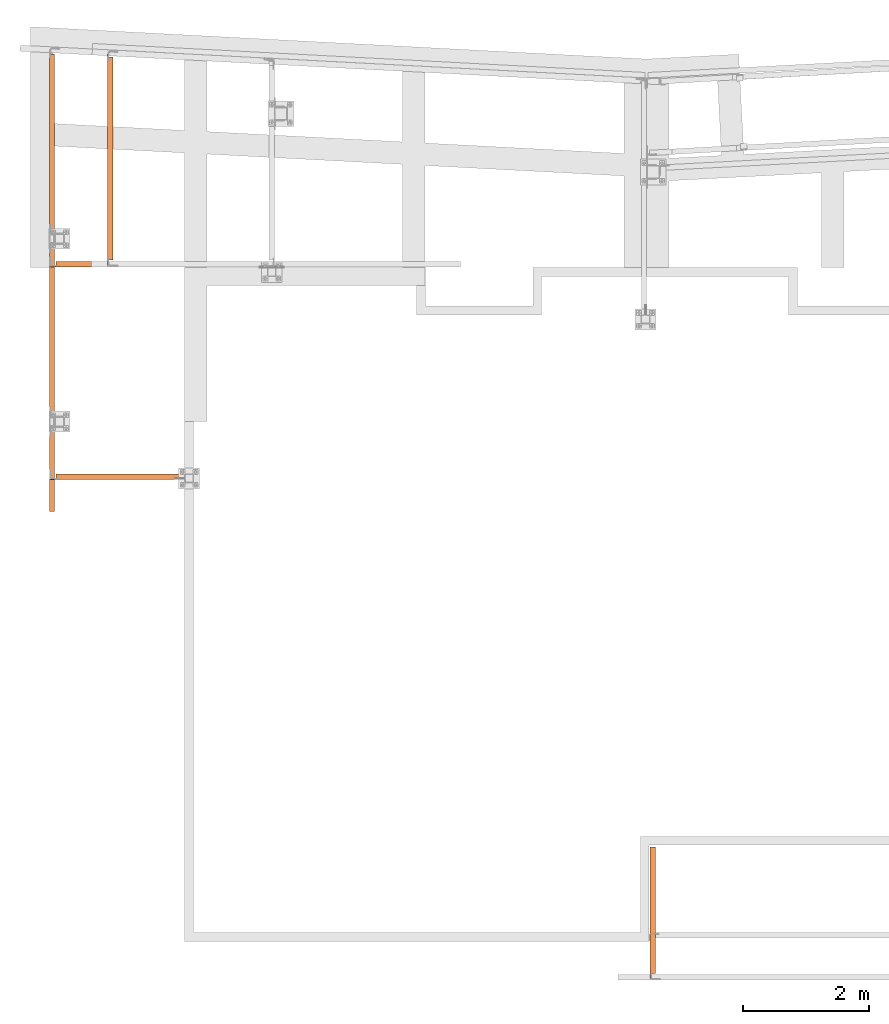
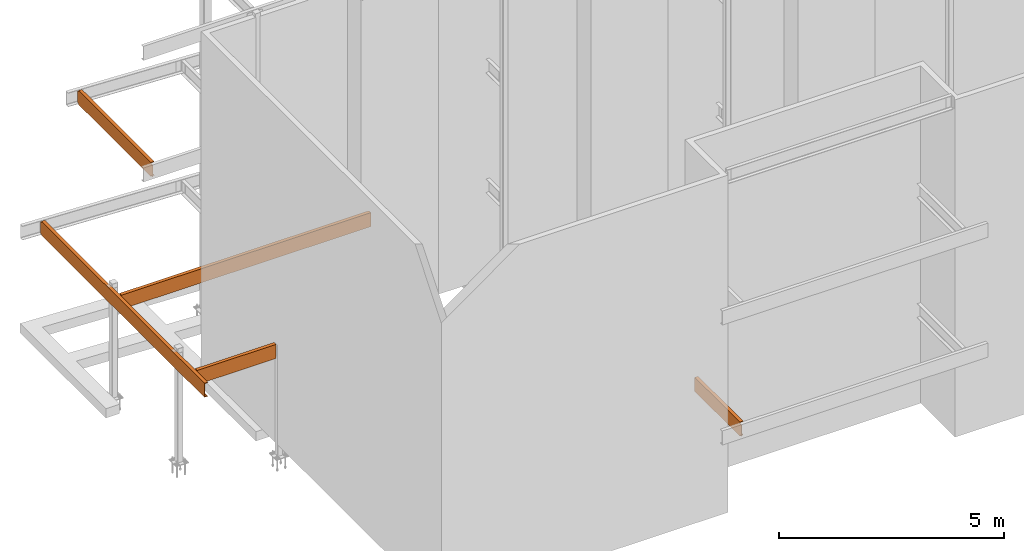
# One storey, part 11 of 89: 5 proxies.
"""IFC4 building model written with IfcOpenShell, lengths in feet."""

from ifc_helpers import new_model, entity, si_unit, converted_unit, derived_unit, direction, frame, origin, place, context, subcontext, project, spatial, faceted_brep, source, transform, mapped, material, constituent, constituent_set, type_object, type_shapes, element, save


model = new_model("IFC4")

# Units and contexts
model_context = context("Model", 3, precision=0.0001, world=origin(), true_north=direction((6.12303176911189e-17, 1.0)))
body_context = subcontext(model_context, "Body", "Model", "MODEL_VIEW")
ifc_project = project(units=[converted_unit("LENGTHUNIT", "FOOT", entity("IfcRatioMeasure", 0.3048), si_unit("LENGTHUNIT", "METRE"), dimensions=[1, 0, 0, 0, 0, 0, 0]), converted_unit("AREAUNIT", "SQUARE FOOT", entity("IfcRatioMeasure", 0.09290304), si_unit("AREAUNIT", "SQUARE_METRE"), dimensions=[2, 0, 0, 0, 0, 0, 0]), converted_unit("VOLUMEUNIT", "CUBIC FOOT", entity("IfcRatioMeasure", 0.028316846592), si_unit("VOLUMEUNIT", "CUBIC_METRE"), dimensions=[3, 0, 0, 0, 0, 0, 0]), si_unit("PLANEANGLEUNIT", "RADIAN"), si_unit("MASSUNIT", "GRAM", prefix="KILO"), derived_unit("MASSDENSITYUNIT", [(si_unit("MASSUNIT", "GRAM", prefix="KILO"), 1), (si_unit("LENGTHUNIT", "METRE"), -3)]), derived_unit("MOMENTOFINERTIAUNIT", [(si_unit("LENGTHUNIT", "METRE"), 4)]), si_unit("TIMEUNIT", "SECOND"), si_unit("FREQUENCYUNIT", "HERTZ"), si_unit("THERMODYNAMICTEMPERATUREUNIT", "DEGREE_CELSIUS"), derived_unit("THERMALTRANSMITTANCEUNIT", [(si_unit("MASSUNIT", "GRAM", prefix="KILO"), 1), (si_unit("THERMODYNAMICTEMPERATUREUNIT", "KELVIN"), -1), (si_unit("TIMEUNIT", "SECOND"), -3)]), derived_unit("VOLUMETRICFLOWRATEUNIT", [(si_unit("LENGTHUNIT", "METRE"), 3), (si_unit("TIMEUNIT", "SECOND"), -1)]), si_unit("ELECTRICCURRENTUNIT", "AMPERE"), si_unit("ELECTRICVOLTAGEUNIT", "VOLT"), si_unit("POWERUNIT", "WATT"), si_unit("FORCEUNIT", "NEWTON"), si_unit("ILLUMINANCEUNIT", "LUX"), si_unit("LUMINOUSFLUXUNIT", "LUMEN"), si_unit("LUMINOUSINTENSITYUNIT", "CANDELA"), derived_unit("USERDEFINED", [(si_unit("MASSUNIT", "GRAM", prefix="KILO"), -1), (si_unit("LENGTHUNIT", "METRE"), -2), (si_unit("TIMEUNIT", "SECOND"), 3), (si_unit("LUMINOUSFLUXUNIT", "LUMEN"), 1)]), derived_unit("LINEARVELOCITYUNIT", [(si_unit("LENGTHUNIT", "METRE"), 1), (si_unit("TIMEUNIT", "SECOND"), -1)]), si_unit("PRESSUREUNIT", "PASCAL"), derived_unit("USERDEFINED", [(si_unit("LENGTHUNIT", "METRE"), -2), (si_unit("MASSUNIT", "GRAM", prefix="KILO"), 1), (si_unit("TIMEUNIT", "SECOND"), -2)]), derived_unit("LINEARFORCEUNIT", [(si_unit("MASSUNIT", "GRAM", prefix="KILO"), 1), (si_unit("LENGTHUNIT", "METRE"), 1), (si_unit("TIMEUNIT", "SECOND"), -2), (si_unit("LENGTHUNIT", "METRE"), -1)]), derived_unit("PLANARFORCEUNIT", [(si_unit("MASSUNIT", "GRAM", prefix="KILO"), 1), (si_unit("LENGTHUNIT", "METRE"), 1), (si_unit("TIMEUNIT", "SECOND"), -2), (si_unit("LENGTHUNIT", "METRE"), -2)])], contexts=[model_context])

# Site, building, storey
site_placement = place(None, origin())
site = spatial("IfcSite", under=ifc_project, at=site_placement, CompositionType="ELEMENT")
building_placement = place(site_placement, frame((-472.238160486, -49.138065117, 0.0)))
building = spatial("IfcBuilding", under=site, at=building_placement, CompositionType="ELEMENT")
storey_placement = place(building_placement, origin())
storey = spatial("IfcBuildingStorey", under=building, at=storey_placement, Name="Level 1", CompositionType="ELEMENT", Elevation=0.0)

# Proxies
ifc_material_1 = material(Name="Color 7720", Category="Materials")
ifc_material_2 = material()
ifc_constituent_1 = constituent(ifc_material_2)
ifc_constituent_2 = constituent(ifc_material_1, Name="Color 7720", Category="Materials")
ifc_constituent_set_1 = constituent_set(constituents=[ifc_constituent_1, ifc_constituent_2])
building_element_proxy_type_1 = type_object("IfcBuildingElementProxyType", Name="c271", PredefinedType="NOTDEFINED", material=ifc_constituent_set_1)
shared_shape_1 = source(origin(), body_context, "Body", "Brep", [
    faceted_brep([(0.0333333333333314, 0.0, 1.125), (0.0, 0.0, 1.125), (0.0, 0.0, 0.125), (0.0333333333333314, 0.0, 0.125), (0.283333333333331, 6.84374999999966, 1.25), (0.283333333333331, 6.84374999999966, 1.21666594419212), (0.0775163152265748, 6.84374999999966, 1.18236429742145), (0.06009413825808, 6.84374999999966, 1.17618476966831), (0.0458638286993107, 6.84374999999966, 1.16438573990163), (0.0365646960660513, 6.84374999999966, 1.14840935276805), (0.0333333333333314, 6.84374999999966, 1.13020833333333), (0.0333333333333314, 6.84374999999966, 0.11979166666667), (0.0365646960660513, 6.84374999999966, 0.10159064723195), (0.0458638286993107, 6.84374999999966, 0.0856142600983691), (0.06009413825808, 6.84374999999966, 0.0738152303316895), (0.0775163152265748, 6.84374999999966, 0.0676357025785492), (0.283333333333331, 6.84374999999966, 0.0333340558078792), (0.283333333333331, 6.84374999999966, 0.0), (0.0, 6.84374999999966, 0.0), (0.0, 6.84374999999966, 1.25), (0.0, 0.267661647187992, 0.0992784763485499), (0.0, 0.258629449216187, 0.11279611588277), (0.0, 0.24511180968193, 0.121828313854641), (0.0, 0.229166666666742, 0.125), (0.0, 0.229166666666742, 1.125), (0.0, 0.24511180968193, 1.12817168614536), (0.0, 0.258629449216187, 1.13720388411723), (0.0, 0.267661647187992, 1.15072152365145), (0.0, 0.270833333333371, 1.16666666666667), (0.0, 0.270833333333371, 1.25), (0.0, 0.270833333333371, 0.0), (0.0, 0.270833333333371, 0.0833333333333304), (0.0750833333333389, 0.270833333333371, 0.0), (0.283333333333331, 0.270833333333371, 0.0), (0.283333333333331, 0.270833333333371, 0.0333340558078792), (0.0775163152265748, 0.270833333333371, 0.0676357025785492), (0.06009413825808, 0.270833333333371, 0.073815230331693), (0.0750833333333389, 0.270833333333371, 0.0684986647192396), (0.0458638286993391, 0.270379628790693, 0.0856142600983834), (0.0486147577663019, 0.270833333333371, 0.0833333333333552), (0.0365646960660229, 0.266116703996545, 0.101590647231946), (0.0379105062004328, 0.267661647187992, 0.099278476348541), (0.0333333333333314, 0.248159867599952, 0.11979166666667), (0.0345753056403737, 0.258629449216187, 0.112796115882773), (0.0333333333333599, 0.24511180968193, 0.121828313854641), (0.0333333333333599, 0.248159867599952, 1.13020833333333), (0.0333333333333599, 0.24511180968193, 1.12817168614536), (0.0333333333333599, 0.229166666666742, 1.125), (0.0333333333333599, 0.229166666666742, 0.125), (0.0365646960660513, 0.266116703996545, 1.14840935276805), (0.0345753056403737, 0.258629449216187, 1.13720388411722), (0.0458638286992823, 0.270379628790693, 1.16438573990164), (0.0379105062004328, 0.267661647187992, 1.15072152365146), (0.06009413825808, 0.270833333333371, 1.17618476966832), (0.0486147577663019, 0.270833333333371, 1.16666666666669), (0.0750833333333389, 0.270833333333371, 1.18150133528076), (0.0775163152265748, 0.270833333333371, 1.18236429742144), (0.283333333333331, 0.270833333333371, 1.21666594419212), (0.283333333333331, 0.270833333333371, 1.25), (0.0750833333333389, 0.270833333333371, 1.25)], [[[0, 1, 2, 3]], [[4, 5, 6, 7, 8, 9, 10, 11, 12, 13, 14, 15, 16, 17, 18, 19]], [[20, 21, 22, 23, 2, 1, 24, 25, 26, 27, 28, 29, 19, 18, 30, 31]], [[32, 30, 18, 17, 33]], [[33, 17, 16, 34]], [[34, 16, 15, 35]], [[35, 15, 14, 36, 37]], [[14, 13, 38, 39, 36]], [[13, 12, 40, 41, 38]], [[12, 11, 42, 43, 40]], [[44, 42, 11, 10, 45, 46, 47, 0, 3, 48]], [[10, 9, 49, 50, 45]], [[9, 8, 51, 52, 49]], [[8, 7, 53, 54, 51]], [[55, 53, 7, 6, 56]], [[56, 6, 5, 57]], [[57, 5, 4, 58]], [[58, 4, 19, 29, 59]], [[24, 1, 0, 47]], [[25, 24, 47, 46]], [[26, 25, 46, 45, 50]], [[27, 26, 50, 49, 52]], [[28, 27, 52, 51, 54]], [[56, 57, 58, 59, 29, 28, 54, 53, 55]], [[34, 33, 32, 30, 31, 39, 36, 37, 35]], [[20, 31, 39, 38, 41]], [[21, 20, 41, 40, 43]], [[22, 21, 43, 42, 44]], [[44, 48, 23, 22]], [[48, 3, 2, 23]]]),
])
type_shapes(building_element_proxy_type_1, [shared_shape_1])
proxy_1_placement = place(building_placement, frame((230.666666666667, 971.072916666667, 8.52083333333333)))
element("IfcBuildingElementProxy", 1, at=proxy_1_placement, inside=storey, type_object=building_element_proxy_type_1, material=ifc_material_1, Name="c271:c271", ObjectType="c271:c271", PredefinedType="NOTDEFINED", context=body_context, shape_type="MappedRepresentation", body=[
    mapped(shared_shape_1, transform((0.0, 0.0, 0.0), scale=1.0)),
])
ifc_constituent_3 = constituent(ifc_material_2)
ifc_constituent_4 = constituent(ifc_material_1, Name="Color 7720", Category="Materials")
ifc_constituent_set_2 = constituent_set(constituents=[ifc_constituent_3, ifc_constituent_4])
building_element_proxy_type_2 = type_object("IfcBuildingElementProxyType", Name="c732", PredefinedType="NOTDEFINED", material=ifc_constituent_set_2)
shared_shape_2 = source(origin(), body_context, "Body", "Brep", [
    faceted_brep([(0.0, 0.0, 1.25), (0.0, 0.0, 0.0), (0.283333333333331, 0.0, 0.0), (0.283333333333331, 0.0, 0.0333340558078827), (0.0775163152265748, 0.0, 0.0676357025785528), (0.0600941382581084, 0.0, 0.073815230331693), (0.0458638286993107, 0.0, 0.0856142600983727), (0.0365646960660513, 0.0, 0.101590647231953), (0.0333333333333314, 0.0, 0.119791666666673), (0.0333333333333314, 0.0, 1.13020833333334), (0.0365646960660513, 0.0, 1.14840935276805), (0.0458638286993107, 0.0, 1.16438573990164), (0.0600941382581084, 0.0, 1.17618476966831), (0.0775163152265748, 0.0, 1.18236429742145), (0.283333333333331, 0.0, 1.21666594419212), (0.283333333333331, 0.0, 1.25), (0.0, 23.9212245567654, 0.125000000000004), (0.0, 23.9212245567654, 1.125), (0.0333333333333314, 23.9212245567654, 1.125), (0.0333333333333314, 23.9212245567654, 0.125000000000004), (0.0, 23.8011127470835, 0.121828313854643), (0.0, 23.7875951075494, 0.112796115882771), (0.0, 23.7785629095774, 0.0992784763485517), (0.0, 23.7753912234321, 0.0833333333333321), (0.0, 23.7753912234321, 0.0), (0.0, 23.7753912234321, 1.25), (0.0, 23.7753912234321, 1.16666666666667), (0.0, 23.7785629095774, 1.15072152365146), (0.0, 23.7875951075494, 1.13720388411723), (0.0, 23.8011127470835, 1.12817168614536), (0.0, 23.8170578900988, 1.125), (0.0, 23.8170578900988, 0.125000000000002), (0.283333333333331, 23.7657285498773, 0.0), (0.0989583333333428, 23.7753912234321, 0.0), (0.283333333333331, 23.7657285498773, 0.0333340558078827), (0.0989583333333428, 23.7753912234321, 0.0640621568245852), (0.0775163152265748, 23.7753912234321, 0.0676357025785439), (0.0600941382581084, 23.7753912234321, 0.073815230331693), (0.0458638286993107, 23.7758449279747, 0.0856142600983727), (0.0486147577662734, 23.7753912234321, 0.0833333333333535), (0.0365646960660513, 23.780107852769, 0.101590647231959), (0.0379105062004612, 23.7785629095774, 0.0992784763485624), (0.0333333333333314, 23.7980646891655, 0.119791666666673), (0.0345753056403737, 23.7875951075494, 0.112796115882777), (0.033333333333303, 23.8170578900988, 0.125000000000004), (0.033333333333303, 23.8170578900988, 1.125), (0.033333333333303, 23.8011127470835, 1.12817168614537), (0.033333333333303, 23.7980646891655, 1.13020833333334), (0.033333333333303, 23.8011127470835, 0.121828313854644), (0.0365646960660513, 23.780107852769, 1.14840935276805), (0.0345753056403737, 23.7875951075494, 1.13720388411723), (0.0458638286993107, 23.7758449279747, 1.16438573990163), (0.0379105062004612, 23.7785629095774, 1.15072152365145), (0.0600941382581084, 23.7753912234321, 1.17618476966831), (0.0486147577662734, 23.7753912234321, 1.16666666666666), (0.0775163152265748, 23.7753912234321, 1.18236429742145), (0.283333333333331, 23.7657285498773, 1.21666594419212), (0.0989583333333428, 23.7753912234321, 1.18593784317541), (0.283333333333331, 23.7657285498773, 1.25), (0.0989583333333428, 23.7753912234321, 1.25000000000001)], [[[0, 1, 2, 3, 4, 5, 6, 7, 8, 9, 10, 11, 12, 13, 14, 15]], [[16, 17, 18, 19]], [[20, 21, 22, 23, 24, 1, 0, 25, 26, 27, 28, 29, 30, 17, 16, 31]], [[32, 2, 1, 24, 33]], [[34, 3, 2, 32]], [[35, 36, 4, 3, 34]], [[37, 5, 4, 36]], [[38, 6, 5, 37, 39]], [[40, 7, 6, 38, 41]], [[42, 8, 7, 40, 43]], [[44, 19, 18, 45, 46, 47, 9, 8, 42, 48]], [[49, 10, 9, 47, 50]], [[51, 11, 10, 49, 52]], [[53, 12, 11, 51, 54]], [[55, 13, 12, 53]], [[56, 14, 13, 55, 57]], [[58, 15, 14, 56]], [[59, 25, 0, 15, 58]], [[57, 59, 25, 26, 54, 53, 55]], [[52, 27, 26, 54, 51]], [[50, 28, 27, 52, 49]], [[46, 29, 28, 50, 47]], [[29, 46, 45, 30]], [[17, 30, 45, 18]], [[59, 58, 56, 57]], [[19, 44, 31, 16]], [[48, 20, 31, 44]], [[43, 21, 20, 48, 42]], [[41, 22, 21, 43, 40]], [[39, 23, 22, 41, 38]], [[33, 24, 23, 39, 37, 36, 35]], [[34, 32, 33, 35]]]),
])
type_shapes(building_element_proxy_type_2, [shared_shape_2])
proxy_2_placement = place(building_placement, frame((199.466666666667, 995.322916666667, 8.35416666666666)))
element("IfcBuildingElementProxy", 2, at=proxy_2_placement, inside=storey, type_object=building_element_proxy_type_2, material=ifc_material_1, Name="c732:c732", ObjectType="c732:c732", PredefinedType="NOTDEFINED", context=body_context, shape_type="MappedRepresentation", body=[
    mapped(shared_shape_2, transform((0.0, 0.0, 0.0), scale=1.0)),
])
ifc_constituent_5 = constituent(ifc_material_2)
ifc_constituent_6 = constituent(ifc_material_1, Name="Color 7720", Category="Materials")
ifc_constituent_set_3 = constituent_set(constituents=[ifc_constituent_5, ifc_constituent_6])
building_element_proxy_type_3 = type_object("IfcBuildingElementProxyType", Name="c430", PredefinedType="NOTDEFINED", material=ifc_constituent_set_3)
shared_shape_3 = source(origin(), body_context, "Body", "Brep", [
    faceted_brep([(0.0, 0.0, 0.125000000000004), (0.0, 0.0, 1.125), (0.0, 0.033333333333303, 1.125), (0.0, 0.033333333333303, 0.125000000000004), (6.91874999999996, 0.0, 1.25), (6.91874999999996, 0.0, 0.0), (6.91874999999996, 0.283333333333303, 0.0), (6.91874999999996, 0.283333333333303, 0.0333340558078827), (6.91874999999996, 0.0775163152266032, 0.0676357025785528), (6.91874999999996, 0.0600941382581368, 0.073815230331693), (6.91874999999996, 0.0458638286992255, 0.0856142600983727), (6.91874999999996, 0.036564696065966, 0.101590647231953), (6.91874999999996, 0.033333333333303, 0.119791666666673), (6.91874999999996, 0.033333333333303, 1.13020833333334), (6.91874999999996, 0.036564696065966, 1.14840935276805), (6.91874999999996, 0.0458638286992255, 1.16438573990164), (6.91874999999996, 0.0600941382581368, 1.17618476966831), (6.91874999999996, 0.0775163152266032, 1.18236429742145), (6.91874999999996, 0.283333333333303, 1.21666594419212), (6.91874999999996, 0.283333333333303, 1.25), (0.270833333333343, 0.283333333333303, 1.25), (0.270833333333343, 0.283333333333303, 1.21666594419212), (0.270833333333343, 0.0775163152266032, 1.18236429742145), (0.270833333333343, 0.0600941382581368, 1.17618476966826), (0.270833333333343, 0.0750833333332821, 1.18150133528068), (0.270379628790693, 0.0458638286992255, 1.16438573990165), (0.270833333333343, 0.048614757766245, 1.16666666666669), (0.266116703996488, 0.036564696065966, 1.14840935276803), (0.267661647187964, 0.0379105062004328, 1.15072152365152), (0.248159867599924, 0.0333333333335304, 1.13020833333329), (0.25862944921613, 0.0345753056406011, 1.1372038841172), (0.229166666666686, 0.0333333333331893, 0.125000000000004), (0.229166666666686, 0.0333333333331893, 1.125), (0.245111809681902, 0.0333333333331893, 1.12817168614537), (0.248159867599924, 0.0333333333331893, 0.119791666666673), (0.245111809681902, 0.0333333333331893, 0.121828313854644), (0.266116703996488, 0.036564696065966, 0.101590647231964), (0.25862944921613, 0.0345753056403737, 0.11279611588277), (0.270379628790693, 0.0458638286994528, 0.0856142600984739), (0.267661647187964, 0.0379105062006602, 0.0992784763485695), (0.270833333333343, 0.0600941382582505, 0.0738152303317801), (0.270833333333343, 0.0486147577663587, 0.0833333333334156), (0.270833333333343, 0.0750833333332821, 0.0684986647193178), (0.270833333333343, 0.0775163152266032, 0.0676357025785972), (0.270833333333343, 0.283333333333303, 0.0333340558078827), (0.270833333333343, 0.283333333333303, 0.0), (0.270833333333343, 0.0, 0.0), (0.270833333333343, 0.0750833333332821, 0.0), (0.245111809681902, 0.0, 0.121828313854644), (0.25862944921613, 0.0, 0.112796115882773), (0.267661647187964, 0.0, 0.0992784763485535), (0.270833333333343, 0.0, 0.0833333333333339), (0.270833333333343, 0.0, 1.25), (0.270833333333343, 0.0, 1.16666666666667), (0.267661647187964, 0.0, 1.15072152365146), (0.25862944921613, 0.0, 1.13720388411723), (0.245111809681902, 0.0, 1.12817168614537), (0.229166666666686, 0.0, 1.125), (0.229166666666686, 0.0, 0.125000000000004), (0.270833333333343, 0.0750833333332821, 1.25000000000001)], [[[0, 1, 2, 3]], [[4, 5, 6, 7, 8, 9, 10, 11, 12, 13, 14, 15, 16, 17, 18, 19]], [[20, 19, 18, 21]], [[21, 18, 17, 22]], [[22, 17, 16, 23, 24]], [[16, 15, 25, 26, 23]], [[15, 14, 27, 28, 25]], [[14, 13, 29, 30, 27]], [[31, 3, 2, 32, 33, 29, 13, 12, 34, 35]], [[12, 11, 36, 37, 34]], [[11, 10, 38, 39, 36]], [[10, 9, 40, 41, 38]], [[42, 40, 9, 8, 43]], [[43, 8, 7, 44]], [[44, 7, 6, 45]], [[45, 6, 5, 46, 47]], [[48, 49, 50, 51, 46, 5, 4, 52, 53, 54, 55, 56, 57, 1, 0, 58]], [[59, 52, 4, 19, 20]], [[32, 2, 1, 57]], [[33, 32, 57, 56]], [[56, 55, 30, 29, 33]], [[55, 54, 28, 27, 30]], [[54, 53, 26, 25, 28]], [[22, 21, 20, 59, 52, 53, 26, 23, 24]], [[44, 45, 47, 46, 51, 41, 40, 42, 43]], [[51, 50, 39, 38, 41]], [[50, 49, 37, 36, 39]], [[49, 48, 35, 34, 37]], [[48, 58, 31, 35]], [[58, 0, 3, 31]]]),
])
type_shapes(building_element_proxy_type_3, [shared_shape_3])
proxy_3_placement = place(building_placement, frame((199.539583333334, 997.0, 8.35416666666666)))
element("IfcBuildingElementProxy", 3, at=proxy_3_placement, inside=storey, type_object=building_element_proxy_type_3, material=ifc_material_1, Name="c430:c430", ObjectType="c430:c430", PredefinedType="NOTDEFINED", context=body_context, shape_type="MappedRepresentation", body=[
    mapped(shared_shape_3, transform((0.0, 0.0, 0.0), scale=1.0)),
])
ifc_constituent_7 = constituent(ifc_material_2)
ifc_constituent_8 = constituent(ifc_material_1, Name="Color 7720", Category="Materials")
ifc_constituent_set_4 = constituent_set(constituents=[ifc_constituent_7, ifc_constituent_8])
building_element_proxy_type_4 = type_object("IfcBuildingElementProxyType", Name="c728", PredefinedType="NOTDEFINED", material=ifc_constituent_set_4)
shared_shape_4 = source(origin(), body_context, "Body", "Brep", [
    faceted_brep([(0.0, 0.0, 0.125000000000009), (0.0, 0.0, 1.12500000000001), (0.0, 0.033333333333303, 1.12500000000001), (0.0, 0.033333333333303, 0.125000000000009), (21.2604166666667, 0.0, 1.25000000000001), (21.2604166666667, 0.0, 0.0), (21.2604166666667, 0.283333333333303, 0.0), (21.2604166666667, 0.283333333333303, 0.0333340558078881), (21.2604166666667, 0.0775163152266032, 0.0676357025785581), (21.2604166666667, 0.0600941382581368, 0.0738152303316983), (21.2604166666667, 0.0458638286992255, 0.085614260098378), (21.2604166666667, 0.036564696065966, 0.101590647231959), (21.2604166666667, 0.033333333333303, 0.119791666666679), (21.2604166666667, 0.033333333333303, 1.13020833333334), (21.2604166666667, 0.036564696065966, 1.14840935276806), (21.2604166666667, 0.0458638286992255, 1.16438573990164), (21.2604166666667, 0.0600941382581368, 1.17618476966832), (21.2604166666667, 0.0775163152266032, 1.18236429742146), (21.2604166666667, 0.283333333333303, 1.21666594419213), (21.2604166666667, 0.283333333333303, 1.25000000000001), (0.270833333333343, 0.283333333333303, 1.25000000000001), (0.270833333333343, 0.283333333333303, 1.21666594419213), (0.270833333333343, 0.0775163152266032, 1.18236429742146), (0.270833333333343, 0.0600941382581368, 1.17618476966834), (0.270833333333343, 0.0750833333332821, 1.18150133528076), (0.270379628790693, 0.0458638286992255, 1.16438573990158), (0.270833333333343, 0.048614757766245, 1.16666666666662), (0.266116703996488, 0.036564696065966, 1.14840935276803), (0.267661647187964, 0.0379105062004328, 1.15072152365152), (0.248159867599924, 0.033333333333303, 1.13020833333333), (0.25862944921613, 0.0345753056403737, 1.13720388411724), (0.229166666666686, 0.0333333333334167, 0.125000000000009), (0.229166666666686, 0.0333333333334167, 1.12500000000001), (0.245111809681902, 0.0333333333334167, 1.12817168614537), (0.248159867599924, 0.0333333333334167, 0.119791666666679), (0.245111809681902, 0.0333333333334167, 0.12182831385465), (0.266116703996488, 0.036564696065966, 0.101590647231969), (0.25862944921613, 0.0345753056403737, 0.112796115882775), (0.270379628790693, 0.0458638286992255, 0.0856142600984064), (0.267661647187964, 0.0379105062004328, 0.0992784763485002), (0.270833333333343, 0.0600941382581368, 0.0738152303317623), (0.270833333333343, 0.048614757766245, 0.0833333333333979), (0.270833333333343, 0.0750833333332821, 0.0684986647192432), (0.270833333333343, 0.0775163152266032, 0.0676357025785226), (0.270833333333343, 0.283333333333303, 0.0333340558078881), (0.270833333333343, 0.283333333333303, 0.0), (0.270833333333343, 0.0, 0.0), (0.270833333333343, 0.0750833333332821, 0.0), (0.245111809681902, 0.0, 0.121828313854651), (0.25862944921613, 0.0, 0.112796115882778), (0.267661647187964, 0.0, 0.0992784763485606), (0.270833333333343, 0.0, 0.083333333333341), (0.270833333333343, 0.0, 1.25000000000001), (0.270833333333343, 0.0, 1.16666666666668), (0.267661647187964, 0.0, 1.15072152365146), (0.25862944921613, 0.0, 1.13720388411724), (0.245111809681902, 0.0, 1.12817168614537), (0.229166666666686, 0.0, 1.12500000000001), (0.229166666666686, 0.0, 0.125000000000011), (0.270833333333343, 0.0750833333332821, 1.25000000000001)], [[[0, 1, 2, 3]], [[4, 5, 6, 7, 8, 9, 10, 11, 12, 13, 14, 15, 16, 17, 18, 19]], [[20, 19, 18, 21]], [[21, 18, 17, 22]], [[22, 17, 16, 23, 24]], [[16, 15, 25, 26, 23]], [[15, 14, 27, 28, 25]], [[14, 13, 29, 30, 27]], [[31, 3, 2, 32, 33, 29, 13, 12, 34, 35]], [[12, 11, 36, 37, 34]], [[11, 10, 38, 39, 36]], [[10, 9, 40, 41, 38]], [[42, 40, 9, 8, 43]], [[43, 8, 7, 44]], [[44, 7, 6, 45]], [[45, 6, 5, 46, 47]], [[48, 49, 50, 51, 46, 5, 4, 52, 53, 54, 55, 56, 57, 1, 0, 58]], [[59, 52, 4, 19, 20]], [[32, 2, 1, 57]], [[33, 32, 57, 56]], [[56, 55, 30, 29, 33]], [[55, 54, 28, 27, 30]], [[54, 53, 26, 25, 28]], [[22, 21, 20, 59, 52, 53, 26, 23, 24]], [[44, 45, 47, 46, 51, 41, 40, 42, 43]], [[51, 50, 39, 38, 41]], [[50, 49, 37, 36, 39]], [[49, 48, 35, 34, 37]], [[48, 58, 31, 35]], [[58, 0, 3, 31]]]),
])
type_shapes(building_element_proxy_type_4, [shared_shape_4])
proxy_4_placement = place(building_placement, frame((199.539583333334, 1008.04166666667, 8.35416666666666)))
element("IfcBuildingElementProxy", 4, at=proxy_4_placement, inside=storey, type_object=building_element_proxy_type_4, material=ifc_material_1, Name="c728:c728", ObjectType="c728:c728", PredefinedType="NOTDEFINED", context=body_context, shape_type="MappedRepresentation", body=[
    mapped(shared_shape_4, transform((0.0, 0.0, 0.0), scale=1.0)),
])
ifc_constituent_9 = constituent(ifc_material_2)
ifc_constituent_10 = constituent(ifc_material_1, Name="Color 7720", Category="Materials")
ifc_constituent_set_5 = constituent_set(constituents=[ifc_constituent_9, ifc_constituent_10])
building_element_proxy_type_5 = type_object("IfcBuildingElementProxyType", Name="c437", PredefinedType="NOTDEFINED", material=ifc_constituent_set_5)
shared_shape_5 = source(origin(), body_context, "Body", "Brep", [
    faceted_brep([(0.0333333333333599, 0.0, 1.125), (0.0, 0.0, 1.125), (0.0, 0.0, 0.125), (0.0333333333333599, 0.0, 0.125), (0.0, 10.971175378538, 0.125), (0.0, 10.971175378538, 1.125), (0.0333333333333599, 10.971175378538, 1.125), (0.0333333333333599, 10.971175378538, 0.125), (0.0, 10.8510635688559, 0.121828313854639), (0.0, 10.8375459293219, 0.11279611588277), (0.0, 10.82851373135, 0.099278476348541), (0.0, 10.8253420452046, 0.0833333333333286), (0.0, 10.8253420452046, 0.0), (0.0, 0.270833333333371, 0.0), (0.0, 0.270833333333371, 0.0833333333333286), (0.0, 0.267661647187992, 0.099278476348541), (0.0, 0.258629449216073, 0.11279611588277), (0.0, 0.24511180968193, 0.121828313854639), (0.0, 0.229166666666742, 0.125), (0.0, 0.229166666666742, 1.125), (0.0, 0.24511180968193, 1.12817168614536), (0.0, 0.258629449216073, 1.13720388411723), (0.0, 0.267661647187992, 1.15072152365146), (0.0, 0.270833333333371, 1.16666666666667), (0.0, 0.270833333333371, 1.25), (0.0, 10.8253420452046, 1.25), (0.0, 10.8253420452046, 1.16666666666667), (0.0, 10.82851373135, 1.15072152365146), (0.0, 10.8375459293219, 1.13720388411723), (0.0, 10.8510635688559, 1.12817168614536), (0.0, 10.8670087118712, 1.125), (0.0, 10.8670087118712, 0.125), (0.28333333333336, 10.8156793716497, 0.0), (0.28333333333336, 0.270833333333371, 0.0), (0.0750833333333389, 0.270833333333371, 0.0), (0.0989583333333712, 10.8253420452046, 0.0), (0.28333333333336, 10.8156793716497, 0.033334055807881), (0.28333333333336, 0.270833333333371, 0.033334055807881), (0.0989583333333712, 10.8253420452046, 0.0640621568245798), (0.0775163152266032, 10.8253420452046, 0.0676357025785386), (0.0775163152266032, 0.270833333333371, 0.0676357025785386), (0.0600941382581368, 10.8253420452046, 0.0738152303317037), (0.0600941382581368, 0.270833333333371, 0.0738152303317037), (0.0750833333333389, 0.270833333333371, 0.0684986647192538), (0.0458638286993676, 10.8257957497472, 0.0856142600983922), (0.0458638286993676, 0.270379628790806, 0.0856142600983922), (0.0486147577663303, 0.270833333333371, 0.0833333333333499), (0.0486147577663303, 10.8253420452046, 0.0833333333333499), (0.0365646960661365, 10.8300586745414, 0.101590647231973), (0.0365646960661365, 0.266116703996431, 0.101590647231973), (0.0379105062005181, 0.267661647187992, 0.0992784763485624), (0.0379105062005181, 10.82851373135, 0.0992784763485624), (0.0333333333333883, 10.848015510938, 0.119791666666675), (0.0333333333333883, 0.248159867599952, 0.119791666666675), (0.0345753056404305, 0.258629449216073, 0.112796115882773), (0.0345753056404305, 10.8375459293219, 0.112796115882773), (0.0333333333333599, 10.8670087118712, 0.125), (0.0333333333333599, 10.8670087118712, 1.125), (0.0333333333333599, 10.8510635688559, 1.12817168614536), (0.0333333333333599, 10.848015510938, 1.13020833333333), (0.0333333333333599, 0.248159867599952, 1.13020833333333), (0.0333333333333599, 0.24511180968193, 1.12817168614536), (0.0333333333333599, 0.229166666666742, 1.125), (0.0333333333333599, 0.229166666666742, 0.125), (0.0333333333333599, 0.24511180968193, 0.121828313854639), (0.0333333333333599, 10.8510635688559, 0.121828313854639), (0.0365646960660797, 10.8300586745414, 1.14840935276805), (0.0365646960660797, 0.266116703996431, 1.14840935276805), (0.0345753056404021, 0.258629449216073, 1.13720388411723), (0.0345753056404021, 10.8375459293219, 1.13720388411723), (0.0458638286993391, 10.8257957497472, 1.16438573990163), (0.0458638286993391, 0.270379628790806, 1.16438573990163), (0.0379105062004612, 0.267661647187992, 1.15072152365145), (0.0379105062004612, 10.82851373135, 1.15072152365145), (0.0600941382581368, 10.8253420452046, 1.17618476966831), (0.0600941382581368, 0.270833333333371, 1.17618476966831), (0.0486147577663019, 0.270833333333371, 1.16666666666667), (0.0486147577663019, 10.8253420452046, 1.16666666666667), (0.0775163152266032, 10.8253420452046, 1.18236429742141), (0.0775163152266032, 0.270833333333371, 1.18236429742141), (0.0750833333333389, 0.270833333333371, 1.18150133528072), (0.28333333333336, 10.8156793716497, 1.21666594419212), (0.28333333333336, 0.270833333333371, 1.21666594419212), (0.0989583333333712, 10.8253420452046, 1.18593784317541), (0.28333333333336, 10.8156793716497, 1.25), (0.28333333333336, 0.270833333333371, 1.25), (0.0989583333333712, 10.8253420452046, 1.25), (0.0750833333333389, 0.270833333333371, 1.25)], [[[0, 1, 2, 3]], [[4, 5, 6, 7]], [[8, 9, 10, 11, 12, 13, 14, 15, 16, 17, 18, 2, 1, 19, 20, 21, 22, 23, 24, 25, 26, 27, 28, 29, 30, 5, 4, 31]], [[32, 33, 34, 13, 12, 35]], [[36, 37, 33, 32]], [[38, 39, 40, 37, 36]], [[41, 42, 43, 40, 39]], [[44, 45, 46, 42, 41, 47]], [[48, 49, 50, 45, 44, 51]], [[52, 53, 54, 49, 48, 55]], [[56, 7, 6, 57, 58, 59, 60, 61, 62, 0, 3, 63, 64, 53, 52, 65]], [[66, 67, 68, 60, 59, 69]], [[70, 71, 72, 67, 66, 73]], [[74, 75, 76, 71, 70, 77]], [[78, 79, 80, 75, 74]], [[81, 82, 79, 78, 83]], [[84, 85, 82, 81]], [[86, 25, 24, 87, 85, 84]], [[19, 1, 0, 62]], [[20, 19, 62, 61]], [[21, 20, 61, 60, 68]], [[22, 21, 68, 67, 72]], [[23, 22, 72, 71, 76]], [[79, 82, 85, 87, 24, 23, 76, 75, 80]], [[37, 33, 34, 13, 14, 46, 42, 43, 40]], [[15, 14, 46, 45, 50]], [[16, 15, 50, 49, 54]], [[17, 16, 54, 53, 64]], [[64, 63, 18, 17]], [[63, 3, 2, 18]], [[83, 86, 25, 26, 77, 74, 78]], [[73, 27, 26, 77, 70]], [[69, 28, 27, 73, 66]], [[58, 29, 28, 69, 59]], [[29, 58, 57, 30]], [[30, 57, 6, 5]], [[86, 84, 81, 83]], [[56, 31, 4, 7]], [[65, 8, 31, 56]], [[55, 9, 8, 65, 52]], [[51, 10, 9, 55, 48]], [[47, 11, 10, 51, 44]], [[35, 12, 11, 47, 41, 39, 38]], [[36, 32, 35, 38]]]),
])
type_shapes(building_element_proxy_type_5, [shared_shape_5])
proxy_5_placement = place(building_placement, frame((202.5, 1008.11458333334, 19.0208333333333)))
element("IfcBuildingElementProxy", 5, at=proxy_5_placement, inside=storey, type_object=building_element_proxy_type_5, material=ifc_material_1, Name="c437:c437", ObjectType="c437:c437", PredefinedType="NOTDEFINED", context=body_context, shape_type="MappedRepresentation", body=[
    mapped(shared_shape_5, transform((0.0, 0.0, 0.0), scale=1.0)),
])

save(model, "model.ifc")
